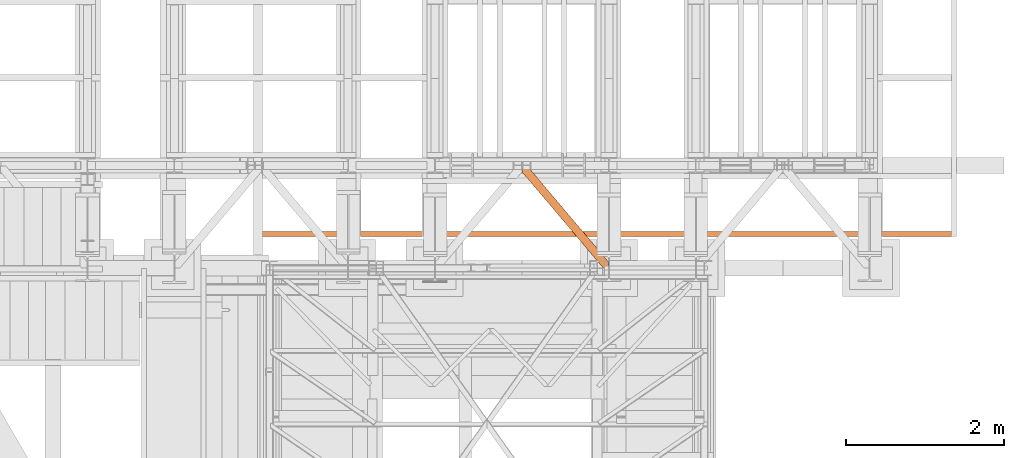
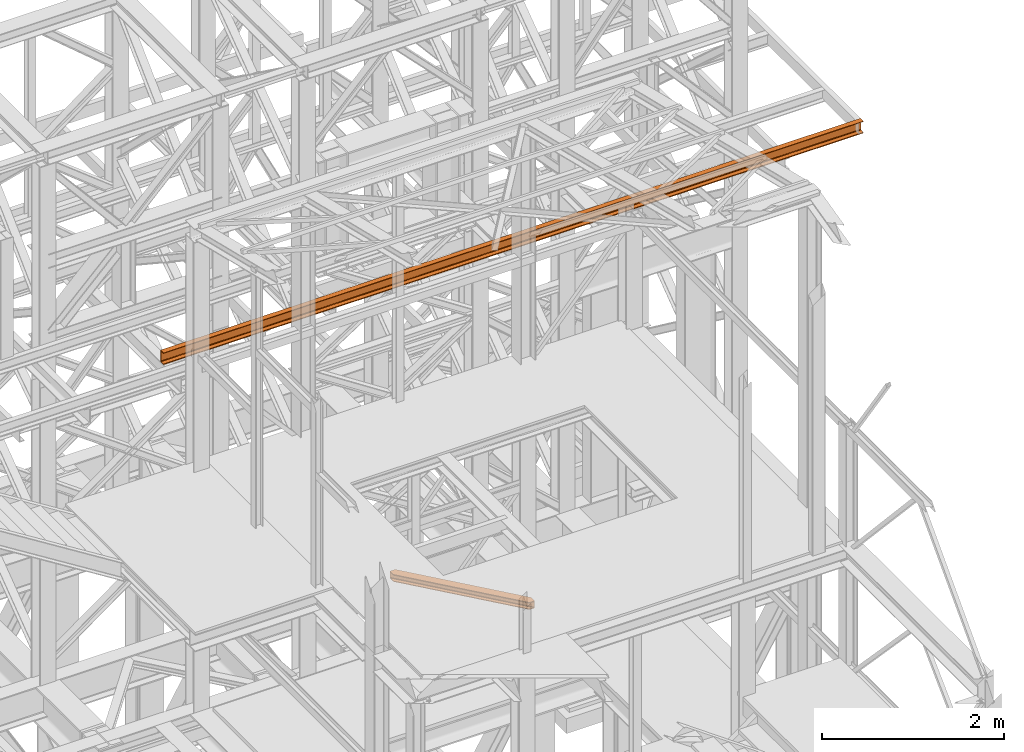
# One storey, part 144 of 208: 2 proxies.
"""IFC2X3 building model written with IfcOpenShell, lengths in millimetres."""

from ifc_helpers import new_model, entity, si_unit, converted_unit, frame, origin, origin_with_axes, place, context, subcontext, project, spatial, faceted_brep, element, save


model = new_model("IFC2X3")

# Units and contexts
model_context = context("Model", 3, precision=1e-05, world=origin())
plan_context = context("Plan", 3, precision=1e-05, world=origin())
body_context = subcontext(model_context, "Body", "Model", "MODEL_VIEW")
ifc_project = project(units=[si_unit("LENGTHUNIT", "METRE", prefix="MILLI"), converted_unit("PLANEANGLEUNIT", "DEGREE", entity("IfcPlaneAngleMeasure", 0.0174532925199433), si_unit("PLANEANGLEUNIT", "RADIAN"), dimensions=[0, 0, 0, 0, 0, 0, 0]), si_unit("AREAUNIT", "SQUARE_METRE"), si_unit("VOLUMEUNIT", "CUBIC_METRE")], contexts=[model_context, plan_context])

# Building, storey
building_placement = place(None, origin())
building = spatial("IfcBuilding", under=ifc_project, at=building_placement, CompositionType="COMPLEX")
storey_placement = place(building_placement, origin_with_axes())
storey = spatial("IfcBuildingStorey", under=building, at=storey_placement, Name="Geschoss", CompositionType="ELEMENT")

# Proxies
proxy_1_placement = place(storey_placement, frame((4393.254968528675, -17257.87439359531, 5101.99001616488), z_axis=(0.0, 0.0, 1.0), x_axis=(1.0, 0.0, 0.0)))
element("IfcBuildingElementProxy", 1, at=proxy_1_placement, inside=storey, context=body_context, shape_type="Brep", body=[
    faceted_brep([(65.50764084493949, 1290.610003345228, 8.010001311303313), (65.50764084493949, 1290.610003345228, 0.01000000000112777), (1094.009999947834, 75.10721531453237, 0.01000000000112777), (1094.009999947834, 75.10721531453237, 8.010001311302403), (65.50764084493949, 1290.610003345228, 0.01000000000112777), (0.01000000000294676, 1290.610003345228, 0.01000000000112777), (0.01000000000294676, 1213.20370052848, 0.01000000000112777), (1026.558515831796, 0.00999999999839929, 0.01000000000021828), (1094.009999947834, 0.00999999999839929, 0.01000000000021828), (1094.009999947834, 75.10721531453237, 0.01000000000112777), (0.01000000000294676, 1213.20370052848, 0.01000000000112777), (0.01000000000112777, 1213.203700528482, 8.010001311303313), (1026.558515831796, 0.00999999999839929, 8.010001311303313), (1026.558515831796, 0.00999999999839929, 0.01000000000021828), (0.01000000000112777, 1213.203700528482, 8.010001311303313), (0.01000000000294676, 1268.162175066993, 8.010001311303313), (1073.061840441306, 0.00999999999839929, 8.010001311303313), (1026.558515831796, 0.00999999999839929, 8.010001311303313), (0.01000000000294676, 1268.162175066993, 8.010001311303313), (0.01000000000203727, 1277.776874373867, 9.253033826352294), (1081.197355239431, 0.00999999999839929, 9.253033826352294), (1073.061840441306, 0.00999999999839929, 8.010001311303313), (0.01000000000203727, 1277.776874373867, 9.253033826352294), (0.01000000000203727, 1284.815317712277, 13.79946006298178), (1087.152961141162, 0.00999999999839929, 13.79946006298178), (1081.197355239431, 0.00999999999839929, 9.253033826352294), (0.01000000000203727, 1284.815317712277, 13.79946006298178), (0.01000000000294676, 1286.739687988116, 20.01000141561144), (1088.781274451488, 0.00999999999839929, 20.01000141561144), (1087.152961141162, 0.00999999999839929, 13.79946006298178), (0.01000000000294676, 1286.739687988116, 20.01000141561144), (0.01000000000294676, 1286.739687988116, 76.01000128150099), (1088.781274451488, 0.00999999999839929, 76.01000128150099), (1088.781274451488, 0.00999999999839929, 20.01000141561144), (0.01000000000294676, 1286.739687988116, 76.01000128150099), (0.01000000000203727, 1284.815317712277, 82.2205407714855), (1087.152961141161, 0.00999999999839929, 82.2205407714855), (1088.781274451488, 0.00999999999839929, 76.01000128150099), (0.01000000000203727, 1284.815317712277, 82.2205407714855), (0.01000000000203727, 1277.776874373867, 86.76696700811499), (1081.197355239431, 0.00999999999839929, 86.76696700811499), (1087.152961141161, 0.00999999999839929, 82.2205407714855), (0.01000000000203727, 1277.776874373867, 86.76696700811499), (0.01000000000203727, 1268.162175066993, 88.00999952316397), (1073.061840441304, 0.00999999999839929, 88.00999952316397), (1081.197355239431, 0.00999999999839929, 86.76696700811499), (0.01000000000203727, 1268.162175066993, 88.00999952316397), (0.01000000000294676, 1213.20370052848, 88.00999952316397), (1026.558515831796, 0.00999999999839929, 88.00999952316397), (1073.061840441304, 0.00999999999839929, 88.00999952316397), (0.01000000000294676, 1213.20370052848, 88.00999952316397), (0.01000000000021828, 1213.203700528484, 96.01000083446615), (1026.558515831796, 0.00999999999839929, 96.01000083446615), (1026.558515831796, 0.00999999999839929, 88.00999952316397), (0.01000000000021828, 1213.203700528484, 96.01000083446615), (0.01000000000112777, 1290.610003345228, 96.01000083446615), (65.50764084493858, 1290.610003345228, 96.01000083446615), (1094.009999947834, 75.10721531453237, 96.01000083446615), (1094.009999947834, 0.00999999999839929, 96.01000083446615), (1026.558515831796, 0.00999999999839929, 96.01000083446615), (65.50764084493858, 1290.610003345228, 96.01000083446615), (65.50764084493858, 1290.610003345228, 88.00999952316397), (1094.009999947834, 75.10721531453237, 88.00999952316397), (1094.009999947834, 75.10721531453237, 96.01000083446615), (65.50764084493858, 1290.610003345228, 88.00999952316397), (19.00431623542772, 1290.610003345228, 88.00999952316397), (1094.009999947834, 20.14874077602144, 88.00999952316397), (1094.009999947834, 75.10721531453237, 88.00999952316397), (19.00431623542772, 1290.610003345228, 88.00999952316397), (10.86880143730195, 1290.610003345228, 86.76696700811499), (1094.009999947834, 10.53404146914545, 86.76696700811499), (1094.009999947834, 20.14874077602144, 88.00999952316397), (10.86880143730195, 1290.610003345228, 86.76696700811499), (4.913195535572413, 1290.610003345228, 82.2205407714855), (1094.009999947834, 3.495598130735743, 82.2205407714855), (1094.009999947834, 10.53404146914545, 86.76696700811499), (4.913195535572413, 1290.610003345228, 82.2205407714855), (3.284882225245383, 1290.610003345228, 76.01000128150099), (1094.009999947833, 1.571227854896279, 76.01000128150099), (1094.009999947834, 3.495598130735743, 82.2205407714855), (3.284882225245383, 1290.610003345228, 76.01000128150099), (3.284882225246292, 1290.610003345228, 20.01000141561144), (1094.009999947834, 1.571227854896279, 20.01000141561144), (1094.009999947833, 1.571227854896279, 76.01000128150099), (3.284882225246292, 1290.610003345228, 20.01000141561144), (4.913195535572413, 1290.610003345228, 13.79946006298178), (1094.009999947834, 3.495598130735743, 13.79946006298178), (1094.009999947834, 1.571227854896279, 20.01000141561144), (4.913195535572413, 1290.610003345228, 13.79946006298178), (10.86880143730286, 1290.610003345228, 9.253033826352294), (1094.009999947834, 10.53404146914545, 9.253033826352294), (1094.009999947834, 3.495598130735743, 13.79946006298178), (10.86880143730286, 1290.610003345228, 9.253033826352294), (19.00431623542954, 1290.610003345228, 8.010001311303313), (1094.009999947834, 20.14874077602144, 8.010001311303313), (1094.009999947834, 10.53404146914545, 9.253033826352294), (19.00431623542954, 1290.610003345228, 8.010001311303313), (65.50764084493949, 1290.610003345228, 8.010001311303313), (1094.009999947834, 75.10721531453237, 8.010001311302403), (1094.009999947834, 20.14874077602144, 8.010001311303313), (0.01000000000294676, 1213.20370052848, 0.01000000000112777), (0.01000000000294676, 1290.610003345228, 0.01000000000112777), (0.01000000000112777, 1290.610003345228, 96.01000083446615), (0.01000000000021828, 1213.203700528484, 96.01000083446615), (0.01000000000294676, 1213.20370052848, 88.00999952316397), (0.01000000000203727, 1268.162175066993, 88.00999952316397), (0.01000000000203727, 1277.776874373867, 86.76696700811499), (0.01000000000203727, 1284.815317712277, 82.2205407714855), (0.01000000000294676, 1286.739687988116, 76.01000128150099), (0.01000000000294676, 1286.739687988116, 20.01000141561144), (0.01000000000203727, 1284.815317712277, 13.79946006298178), (0.01000000000203727, 1277.776874373867, 9.253033826352294), (0.01000000000294676, 1268.162175066993, 8.010001311303313), (0.01000000000112777, 1213.203700528482, 8.010001311303313), (0.01000000000112777, 1290.610003345228, 96.01000083446615), (0.01000000000294676, 1290.610003345228, 0.01000000000112777), (65.50764084493949, 1290.610003345228, 0.01000000000112777), (65.50764084493949, 1290.610003345228, 8.010001311303313), (19.00431623542954, 1290.610003345228, 8.010001311303313), (10.86880143730286, 1290.610003345228, 9.253033826352294), (4.913195535572413, 1290.610003345228, 13.79946006298178), (3.284882225246292, 1290.610003345228, 20.01000141561144), (3.284882225245383, 1290.610003345228, 76.01000128150099), (4.913195535572413, 1290.610003345228, 82.2205407714855), (10.86880143730195, 1290.610003345228, 86.76696700811499), (19.00431623542772, 1290.610003345228, 88.00999952316397), (65.50764084493858, 1290.610003345228, 88.00999952316397), (65.50764084493858, 1290.610003345228, 96.01000083446615), (1094.009999947834, 75.10721531453237, 8.010001311302403), (1094.009999947834, 75.10721531453237, 0.01000000000112777), (1094.009999947834, 0.00999999999839929, 0.01000000000021828), (1094.009999947834, 0.00999999999839929, 96.01000083446615), (1094.009999947834, 75.10721531453237, 96.01000083446615), (1094.009999947834, 75.10721531453237, 88.00999952316397), (1094.009999947834, 20.14874077602144, 88.00999952316397), (1094.009999947834, 10.53404146914545, 86.76696700811499), (1094.009999947834, 3.495598130735743, 82.2205407714855), (1094.009999947833, 1.571227854896279, 76.01000128150099), (1094.009999947834, 1.571227854896279, 20.01000141561144), (1094.009999947834, 3.495598130735743, 13.79946006298178), (1094.009999947834, 10.53404146914545, 9.253033826352294), (1094.009999947834, 20.14874077602144, 8.010001311303313), (1094.009999947834, 0.00999999999839929, 0.01000000000021828), (1026.558515831796, 0.00999999999839929, 0.01000000000021828), (1026.558515831796, 0.00999999999839929, 8.010001311303313), (1073.061840441306, 0.00999999999839929, 8.010001311303313), (1081.197355239431, 0.00999999999839929, 9.253033826352294), (1087.152961141162, 0.00999999999839929, 13.79946006298178), (1088.781274451488, 0.00999999999839929, 20.01000141561144), (1088.781274451488, 0.00999999999839929, 76.01000128150099), (1087.152961141161, 0.00999999999839929, 82.2205407714855), (1081.197355239431, 0.00999999999839929, 86.76696700811499), (1073.061840441304, 0.00999999999839929, 88.00999952316397), (1026.558515831796, 0.00999999999839929, 88.00999952316397), (1026.558515831796, 0.00999999999839929, 96.01000083446615), (1094.009999947834, 0.00999999999839929, 96.01000083446615)], [[[0, 1, 2, 3]], [[4, 5, 6, 7, 8, 9]], [[10, 11, 12, 13]], [[14, 15, 16, 17]], [[18, 19, 20, 21]], [[22, 23, 24, 25]], [[26, 27, 28, 29]], [[30, 31, 32, 33]], [[34, 35, 36, 37]], [[38, 39, 40, 41]], [[42, 43, 44, 45]], [[46, 47, 48, 49]], [[50, 51, 52, 53]], [[54, 55, 56, 57, 58, 59]], [[60, 61, 62, 63]], [[64, 65, 66, 67]], [[68, 69, 70, 71]], [[72, 73, 74, 75]], [[76, 77, 78, 79]], [[80, 81, 82, 83]], [[84, 85, 86, 87]], [[88, 89, 90, 91]], [[92, 93, 94, 95]], [[96, 97, 98, 99]], [[100, 101, 102, 103, 104, 105, 106, 107, 108, 109, 110, 111, 112, 113]], [[114, 115, 116, 117, 118, 119, 120, 121, 122, 123, 124, 125, 126, 127]], [[128, 129, 130, 131, 132, 133, 134, 135, 136, 137, 138, 139, 140, 141]], [[142, 143, 144, 145, 146, 147, 148, 149, 150, 151, 152, 153, 154, 155]]], orient=[[False], [False], [False], [False], [False], [False], [False], [False], [False], [False], [False], [False], [False], [False], [False], [False], [False], [False], [False], [False], [False], [False], [False], [False], [False], [False], [False], [False]]),
])
proxy_2_placement = place(storey_placement, frame((997.4990363434481, -16862.574391808, 9699.99), z_axis=(0.0, 0.0, 1.0), x_axis=(1.0, 0.0, 0.0)))
element("IfcBuildingElementProxy", 2, at=proxy_2_placement, inside=storey, context=body_context, shape_type="Brep", body=[
    faceted_brep([(0.01000000000021828, 0.00999999999839929, 0.01000000000021828), (0.01000000000021828, 0.00999999999839929, 3.132428070246533), (8895.523197098162, 0.00999999999839929, 3.132428070246533), (8895.523197098162, 0.00999999999839929, 0.01000000000021828), (0.01000000000021828, 0.00999999999839929, 3.132428070246533), (0.01000000000021828, 0.2527365771711629, 4.748288908171162), (8895.523197098162, 0.2527365771748009, 4.748288908171162), (8895.523197098162, 0.00999999999839929, 3.132428070246533), (0.01000000000021828, 0.2527365771711629, 4.748288908171162), (0.01000000000021828, 0.9594677141431021, 6.221534443444398), (8895.523197098162, 0.9594677141431021, 6.221534443444398), (8895.523197098162, 0.2527365771748009, 4.748288908171162), (0.01000000000021828, 0.9594677141431021, 6.221534443444398), (0.01000000000021828, 2.067848361530196, 7.422126703873801), (8895.523197098162, 2.067848361530196, 7.422126703873801), (8895.523197098162, 0.9594677141431021, 6.221534443444398), (0.01000000000021828, 2.067848361530196, 7.422126703873801), (0.01000000000021828, 3.4800435885154, 8.244091391710754), (8895.523197098162, 3.4800435885154, 8.244091391710754), (8895.523197098162, 2.067848361530196, 7.422126703873801), (0.01000000000021828, 3.4800435885154, 8.244091391710754), (0.01000000000021828, 5.071401277444238, 8.614912102195376), (8895.523197098162, 5.071401277444238, 8.614912102195376), (8895.523197098162, 3.4800435885154, 8.244091391710754), (0.01000000000021828, 5.071401277444238, 8.614912102195376), (0.01000000000021828, 47.84732483396874, 12.0369859867169), (8895.523197098162, 47.84732483396874, 12.0369859867169), (8895.523197098162, 5.071401277444238, 8.614912102195376), (0.01000000000021828, 47.84732483396874, 12.0369859867169), (0.01000000000021828, 50.88537133101636, 12.74491643400506), (8895.523197098162, 50.88537133101636, 12.74491643400506), (8895.523197098162, 47.84732483396874, 12.0369859867169), (0.01000000000021828, 50.88537133101636, 12.74491643400506), (0.01000000000021828, 53.58138040071208, 14.31412174714933), (8895.523197098162, 53.58138040071208, 14.31412174714933), (8895.523197098162, 50.88537133101636, 12.74491643400506), (0.01000000000021828, 53.58138040071208, 14.31412174714933), (0.01000000000021828, 55.69737981845174, 16.60616151705835), (8895.523197098162, 55.69737981845174, 16.60616151705835), (8895.523197098162, 53.58138040071208, 14.31412174714933), (0.01000000000021828, 55.69737981845174, 16.60616151705835), (0.01000000000021828, 57.04659380721205, 19.41872117530875), (8895.523197098162, 57.04659380721205, 19.41872117530875), (8895.523197098162, 55.69737981845174, 16.60616151705835), (0.01000000000021828, 57.04659380721205, 19.41872117530875), (0.01000000000021828, 57.5099999999984, 22.50354641134618), (8895.523197098162, 57.5099999999984, 22.50354641134618), (8895.523197098162, 57.04659380721205, 19.41872117530875), (0.01000000000021828, 57.5099999999984, 22.50354641134618), (0.01000000000021828, 57.5099999999984, 137.5164535886524), (8895.523197098162, 57.5099999999984, 137.5164535886524), (8895.523197098162, 57.5099999999984, 22.50354641134618), (0.01000000000021828, 57.5099999999984, 137.5164535886524), (0.01000000000021828, 57.04659380721205, 140.6012788246917), (8895.523197098162, 57.04659380721205, 140.6012788246917), (8895.523197098162, 57.5099999999984, 137.5164535886524), (0.01000000000021828, 57.04659380721205, 140.6012788246917), (0.01000000000021828, 55.69737981845174, 143.4138384829403), (8895.523197098162, 55.69737981845174, 143.4138384829403), (8895.523197098162, 57.04659380721205, 140.6012788246917), (0.01000000000021828, 55.69737981845174, 143.4138384829403), (0.01000000000021828, 53.58138040071208, 145.7058782528493), (8895.523197098162, 53.58138040071208, 145.7058782528493), (8895.523197098162, 55.69737981845174, 143.4138384829403), (0.01000000000021828, 53.58138040071208, 145.7058782528493), (0.01000000000021828, 50.88537133101636, 147.2750835659936), (8895.523197098162, 50.88537133101636, 147.2750835659936), (8895.523197098162, 53.58138040071208, 145.7058782528493), (0.01000000000021828, 50.88537133101636, 147.2750835659936), (0.01000000000021828, 47.84732483396874, 147.9830140132817), (8895.523197098162, 47.84732483396874, 147.9830140132817), (8895.523197098162, 50.88537133101636, 147.2750835659936), (0.01000000000021828, 47.84732483396874, 147.9830140132817), (0.01000000000021828, 5.071401277444238, 151.4050878978032), (8895.523197098162, 5.071401277444238, 151.4050878978032), (8895.523197098162, 47.84732483396874, 147.9830140132817), (0.01000000000021828, 5.071401277444238, 151.4050878978032), (0.01000000000021828, 3.4800435885154, 151.7759086082879), (8895.523197098162, 3.4800435885154, 151.7759086082879), (8895.523197098162, 5.071401277444238, 151.4050878978032), (0.01000000000021828, 3.4800435885154, 151.7759086082879), (0.01000000000021828, 2.067848361530196, 152.5978732961248), (8895.523197098162, 2.067848361530196, 152.5978732961248), (8895.523197098162, 3.4800435885154, 151.7759086082879), (0.01000000000021828, 2.067848361530196, 152.5978732961248), (0.01000000000021828, 0.9594677141431021, 153.7984655565542), (8895.523197098162, 0.9594677141431021, 153.7984655565542), (8895.523197098162, 2.067848361530196, 152.5978732961248), (0.01000000000021828, 0.9594677141431021, 153.7984655565542), (0.01000000000021828, 0.2527365771711629, 155.2717110918275), (8895.523197098162, 0.2527365771748009, 155.2717110918275), (8895.523197098162, 0.9594677141431021, 153.7984655565542), (0.01000000000021828, 0.2527365771711629, 155.2717110918275), (0.01000000000021828, 0.00999999999839929, 156.8875719297521), (8895.523197098162, 0.00999999999839929, 156.8875719297521), (8895.523197098162, 0.2527365771748009, 155.2717110918275), (0.01000000000021828, 0.00999999999839929, 156.8875719297521), (0.01000000000021828, 0.00999999999839929, 160.0100000000002), (8895.523197098162, 0.00999999999839929, 160.0100000000002), (8895.523197098162, 0.00999999999839929, 156.8875719297521), (0.01000000000021828, 0.00999999999839929, 160.0100000000002), (0.01000000000021828, 65.0099999999984, 160.0100000000002), (8895.523197098162, 65.0099999999984, 160.0100000000002), (8895.523197098162, 0.00999999999839929, 160.0100000000002), (0.01000000000021828, 65.0099999999984, 160.0100000000002), (0.01000000000021828, 65.0099999999984, 0.01000000000021828), (8895.523197098162, 65.0099999999984, 0.01000000000021828), (8895.523197098162, 65.0099999999984, 160.0100000000002), (0.01000000000021828, 65.0099999999984, 0.01000000000021828), (0.01000000000021828, 0.00999999999839929, 0.01000000000021828), (8895.523197098162, 0.00999999999839929, 0.01000000000021828), (8895.523197098162, 65.0099999999984, 0.01000000000021828), (0.01000000000021828, 0.00999999999839929, 0.01000000000021828), (0.01000000000021828, 65.0099999999984, 0.01000000000021828), (0.01000000000021828, 65.0099999999984, 160.0100000000002), (0.01000000000021828, 0.00999999999839929, 160.0100000000002), (0.01000000000021828, 0.00999999999839929, 156.8875719297521), (0.01000000000021828, 0.2527365771711629, 155.2717110918275), (0.01000000000021828, 0.9594677141431021, 153.7984655565542), (0.01000000000021828, 2.067848361530196, 152.5978732961248), (0.01000000000021828, 3.4800435885154, 151.7759086082879), (0.01000000000021828, 5.071401277444238, 151.4050878978032), (0.01000000000021828, 47.84732483396874, 147.9830140132817), (0.01000000000021828, 50.88537133101636, 147.2750835659936), (0.01000000000021828, 53.58138040071208, 145.7058782528493), (0.01000000000021828, 55.69737981845174, 143.4138384829403), (0.01000000000021828, 57.04659380721205, 140.6012788246917), (0.01000000000021828, 57.5099999999984, 137.5164535886524), (0.01000000000021828, 57.5099999999984, 22.50354641134618), (0.01000000000021828, 57.04659380721205, 19.41872117530875), (0.01000000000021828, 55.69737981845174, 16.60616151705835), (0.01000000000021828, 53.58138040071208, 14.31412174714933), (0.01000000000021828, 50.88537133101636, 12.74491643400506), (0.01000000000021828, 47.84732483396874, 12.0369859867169), (0.01000000000021828, 5.071401277444238, 8.614912102195376), (0.01000000000021828, 3.4800435885154, 8.244091391710754), (0.01000000000021828, 2.067848361530196, 7.422126703873801), (0.01000000000021828, 0.9594677141431021, 6.221534443444398), (0.01000000000021828, 0.2527365771711629, 4.748288908171162), (0.01000000000021828, 0.00999999999839929, 3.132428070246533), (8895.523197098162, 0.00999999999839929, 0.01000000000021828), (8895.523197098162, 0.00999999999839929, 3.132428070246533), (8895.523197098162, 0.2527365771748009, 4.748288908171162), (8895.523197098162, 0.9594677141431021, 6.221534443444398), (8895.523197098162, 2.067848361530196, 7.422126703873801), (8895.523197098162, 3.4800435885154, 8.244091391710754), (8895.523197098162, 5.071401277444238, 8.614912102195376), (8895.523197098162, 47.84732483396874, 12.0369859867169), (8895.523197098162, 50.88537133101636, 12.74491643400506), (8895.523197098162, 53.58138040071208, 14.31412174714933), (8895.523197098162, 55.69737981845174, 16.60616151705835), (8895.523197098162, 57.04659380721205, 19.41872117530875), (8895.523197098162, 57.5099999999984, 22.50354641134618), (8895.523197098162, 57.5099999999984, 137.5164535886524), (8895.523197098162, 57.04659380721205, 140.6012788246917), (8895.523197098162, 55.69737981845174, 143.4138384829403), (8895.523197098162, 53.58138040071208, 145.7058782528493), (8895.523197098162, 50.88537133101636, 147.2750835659936), (8895.523197098162, 47.84732483396874, 147.9830140132817), (8895.523197098162, 5.071401277444238, 151.4050878978032), (8895.523197098162, 3.4800435885154, 151.7759086082879), (8895.523197098162, 2.067848361530196, 152.5978732961248), (8895.523197098162, 0.9594677141431021, 153.7984655565542), (8895.523197098162, 0.2527365771748009, 155.2717110918275), (8895.523197098162, 0.00999999999839929, 156.8875719297521), (8895.523197098162, 0.00999999999839929, 160.0100000000002), (8895.523197098162, 65.0099999999984, 160.0100000000002), (8895.523197098162, 65.0099999999984, 0.01000000000021828)], [[[0, 1, 2, 3]], [[4, 5, 6, 7]], [[8, 9, 10, 11]], [[12, 13, 14, 15]], [[16, 17, 18, 19]], [[20, 21, 22, 23]], [[24, 25, 26, 27]], [[28, 29, 30, 31]], [[32, 33, 34, 35]], [[36, 37, 38, 39]], [[40, 41, 42, 43]], [[44, 45, 46, 47]], [[48, 49, 50, 51]], [[52, 53, 54, 55]], [[56, 57, 58, 59]], [[60, 61, 62, 63]], [[64, 65, 66, 67]], [[68, 69, 70, 71]], [[72, 73, 74, 75]], [[76, 77, 78, 79]], [[80, 81, 82, 83]], [[84, 85, 86, 87]], [[88, 89, 90, 91]], [[92, 93, 94, 95]], [[96, 97, 98, 99]], [[100, 101, 102, 103]], [[104, 105, 106, 107]], [[108, 109, 110, 111]], [[112, 113, 114, 115, 116, 117, 118, 119, 120, 121, 122, 123, 124, 125, 126, 127, 128, 129, 130, 131, 132, 133, 134, 135, 136, 137, 138, 139]], [[140, 141, 142, 143, 144, 145, 146, 147, 148, 149, 150, 151, 152, 153, 154, 155, 156, 157, 158, 159, 160, 161, 162, 163, 164, 165, 166, 167]]], orient=[[False], [False], [False], [False], [False], [False], [False], [False], [False], [False], [False], [False], [False], [False], [False], [False], [False], [False], [False], [False], [False], [False], [False], [False], [False], [False], [False], [False], [False], [False]]),
])

save(model, "model.ifc")
